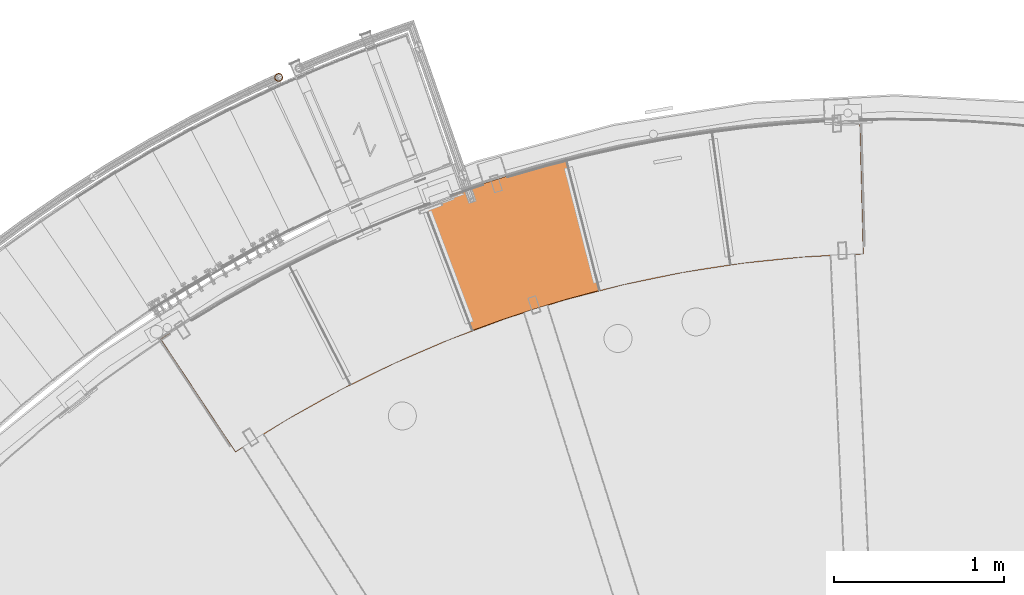
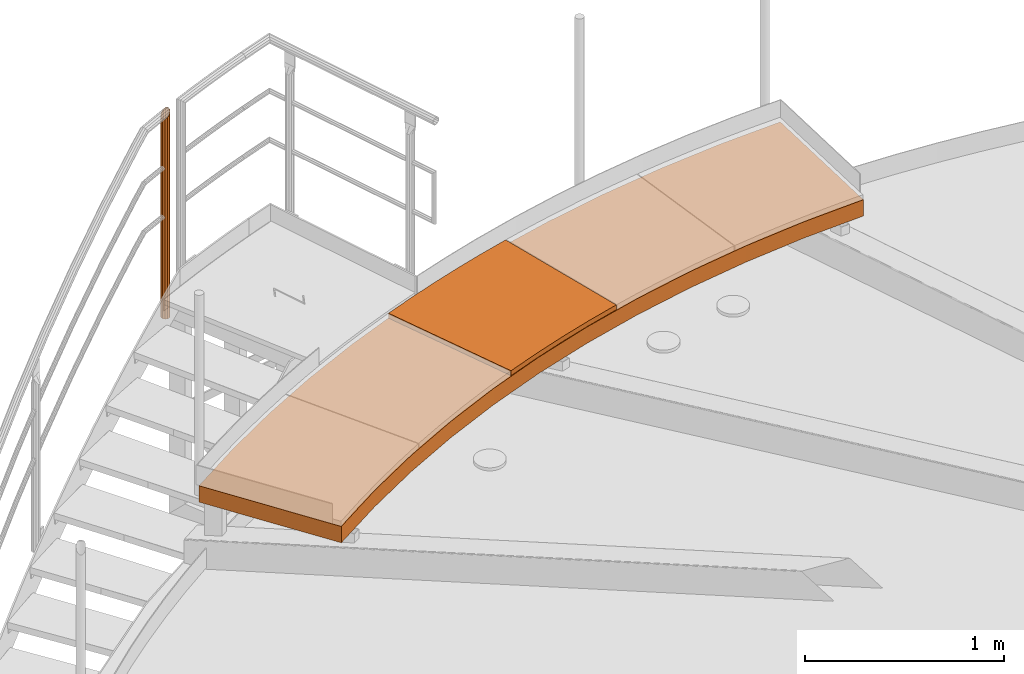
# One storey, part 38 of 126: 3 proxies.
"""IFC2X3 building model written with IfcOpenShell, lengths in millimetres."""

from ifc_helpers import new_model, si_unit, origin, origin_with_axes, place, context, project, spatial, faceted_brep, material, element, save


model = new_model("IFC2X3")

# Units and contexts
context_of_model_1 = context(None, 3, precision=0.1, world=origin())
context_of_model_2 = context(None, 3, precision=0.1, world=origin())
ifc_project = project(units=[si_unit("LENGTHUNIT", "METRE", prefix="MILLI"), si_unit("AREAUNIT", "SQUARE_METRE", prefix="CENTI"), si_unit("VOLUMEUNIT", "CUBIC_METRE", prefix="CENTI"), si_unit("MASSUNIT", "GRAM", prefix="KILO")], contexts=[context_of_model_1, context_of_model_2])

# Site, building, storey
site_placement = place(None, origin_with_axes())
site = spatial("IfcSite", under=ifc_project, at=site_placement, CompositionType="ELEMENT")
building_placement = place(site_placement, origin_with_axes())
building = spatial("IfcBuilding", under=site, at=building_placement, CompositionType="ELEMENT")
storey_placement = place(building_placement, origin_with_axes())
storey = spatial("IfcBuildingStorey", under=building, at=storey_placement, CompositionType="ELEMENT")

# Proxies
ifc_material_1 = material(Name="STAHL")
proxy_1_placement = place(storey_placement, origin_with_axes())
element("IfcBuildingElementProxy", 1, at=proxy_1_placement, inside=storey, material=ifc_material_1, Name="profile", context=context_of_model_2, shape_type="Brep", body=[
    faceted_brep([(3744.3, 14532.7, 10959.2), (4130.7, 13949.0, 10959.2), (4130.7, 13949.0, 10955.2), (3744.3, 14532.7, 10955.2), (3680.6, 14545.7, 10959.2), (3680.6, 14545.7, 11051.2), (4117.7, 13885.3, 11051.2), (4117.7, 13885.3, 10959.2), (3744.3, 14532.7, 11055.2), (4130.7, 13949.0, 11055.2), (4130.7, 13949.0, 11051.2), (3744.3, 14532.7, 11051.2), (3675.1, 14546.8, 11055.2), (3675.1, 14546.8, 10955.2), (4116.6, 13879.7, 10955.2), (4116.6, 13879.7, 11055.2), (4419.8, 14069.5, 10955.2), (4732.2, 14243.6, 10955.2), (5053.0, 14401.7, 10955.2), (5381.5, 14543.3, 10955.2), (5716.7, 14668.0, 10955.2), (6057.8, 14775.5, 10955.2), (6403.9, 14865.6, 10955.2), (6754.1, 14938.1, 10955.2), (7107.6, 14992.6, 10955.2), (7463.4, 15029.2, 10955.2), (7820.6, 15047.6, 10955.2), (7820.6, 15047.6, 11055.2), (7463.4, 15029.2, 11055.2), (7107.6, 14992.6, 11055.2), (6754.1, 14938.1, 11055.2), (6403.9, 14865.6, 11055.2), (6057.8, 14775.5, 11055.2), (5716.7, 14668.0, 11055.2), (5381.5, 14543.3, 11055.2), (5053.0, 14401.7, 11055.2), (4732.2, 14243.6, 11055.2), (4419.8, 14069.5, 11055.2), (4429.5, 14133.4, 10959.2), (4737.1, 14302.8, 10959.2), (5052.6, 14456.7, 10959.2), (5375.4, 14594.9, 10959.2), (5704.7, 14716.9, 10959.2), (6039.5, 14822.5, 10959.2), (6379.2, 14911.4, 10959.2), (6722.9, 14983.4, 10959.2), (7069.7, 15038.3, 10959.2), (7418.8, 15075.9, 10959.2), (7769.3, 15096.3, 10959.2), (7769.3, 15096.3, 10955.2), (7418.8, 15075.9, 10955.2), (7069.7, 15038.3, 10955.2), (6722.9, 14983.4, 10955.2), (6379.2, 14911.4, 10955.2), (6039.5, 14822.5, 10955.2), (5704.7, 14716.9, 10955.2), (5375.4, 14594.9, 10955.2), (5052.6, 14456.7, 10955.2), (4737.1, 14302.8, 10955.2), (4429.5, 14133.4, 10955.2), (4420.5, 14074.6, 11051.2), (4732.6, 14248.4, 11051.2), (5053.0, 14406.1, 11051.2), (5381.0, 14547.4, 11051.2), (5715.7, 14671.9, 11051.2), (6056.3, 14779.3, 11051.2), (6401.9, 14869.3, 11051.2), (6751.6, 14941.7, 11051.2), (7104.6, 14996.3, 11051.2), (7459.8, 15032.9, 11051.2), (7816.5, 15051.5, 11051.2), (7816.5, 15051.5, 10959.2), (7459.8, 15032.9, 10959.2), (7104.6, 14996.3, 10959.2), (6751.6, 14941.7, 10959.2), (6401.9, 14869.3, 10959.2), (6056.3, 14779.3, 10959.2), (5715.7, 14671.9, 10959.2), (5381.0, 14547.4, 10959.2), (5053.0, 14406.1, 10959.2), (4732.6, 14248.4, 10959.2), (4420.5, 14074.6, 10959.2), (4429.5, 14133.4, 11055.2), (4737.1, 14302.8, 11055.2), (5052.6, 14456.7, 11055.2), (5375.4, 14594.9, 11055.2), (5704.7, 14716.9, 11055.2), (6039.5, 14822.5, 11055.2), (6379.2, 14911.4, 11055.2), (6722.9, 14983.4, 11055.2), (7069.7, 15038.3, 11055.2), (7418.8, 15075.9, 11055.2), (7769.3, 15096.3, 11055.2), (7769.3, 15096.3, 11051.2), (7418.8, 15075.9, 11051.2), (7069.7, 15038.3, 11051.2), (6722.9, 14983.4, 11051.2), (6379.2, 14911.4, 11051.2), (6039.5, 14822.5, 11051.2), (5704.7, 14716.9, 11051.2), (5375.4, 14594.9, 11051.2), (5052.6, 14456.7, 11051.2), (4737.1, 14302.8, 11051.2), (4429.5, 14133.4, 11051.2), (4045.5, 14719.7, 11055.2), (4354.8, 14892.7, 11055.2), (4671.7, 15051.5, 11055.2), (4995.4, 15195.8, 11055.2), (5325.4, 15325.1, 11055.2), (5661.0, 15439.4, 11055.2), (6001.3, 15538.2, 11055.2), (6345.8, 15621.5, 11055.2), (6693.8, 15689.1, 11055.2), (7044.4, 15740.8, 11055.2), (7397.1, 15776.4, 11055.2), (7751.0, 15796.0, 11055.2), (7799.6, 15847.3, 11055.2), (7435.0, 15829.3, 11055.2), (7071.6, 15794.3, 11055.2), (6710.2, 15742.4, 11055.2), (6351.6, 15673.8, 11055.2), (5996.6, 15588.6, 11055.2), (5646.0, 15486.9, 11055.2), (5300.4, 15369.1, 11055.2), (4960.7, 15235.2, 11055.2), (4627.6, 15085.8, 11055.2), (4301.9, 14921.0, 11055.2), (3984.1, 14741.2, 11055.2), (7799.6, 15847.3, 10955.2), (3984.1, 14741.2, 10955.2), (4301.9, 14921.0, 10955.2), (4627.6, 15085.8, 10955.2), (4960.7, 15235.2, 10955.2), (5300.4, 15369.1, 10955.2), (5646.0, 15486.9, 10955.2), (5996.6, 15588.6, 10955.2), (6351.6, 15673.8, 10955.2), (6710.2, 15742.4, 10955.2), (7071.6, 15794.3, 10955.2), (7435.0, 15829.3, 10955.2), (7751.0, 15796.0, 10955.2), (7397.1, 15776.4, 10955.2), (7044.4, 15740.8, 10955.2), (6693.8, 15689.1, 10955.2), (6345.8, 15621.5, 10955.2), (6001.3, 15538.2, 10955.2), (5661.0, 15439.4, 10955.2), (5325.4, 15325.1, 10955.2), (4995.4, 15195.8, 10955.2), (4671.7, 15051.5, 10955.2), (4354.8, 14892.7, 10955.2), (4045.5, 14719.7, 10955.2), (7751.0, 15796.0, 10959.2), (4045.5, 14719.7, 10959.2), (4354.8, 14892.7, 10959.2), (4671.7, 15051.5, 10959.2), (4995.4, 15195.8, 10959.2), (5325.4, 15325.1, 10959.2), (5661.0, 15439.4, 10959.2), (6001.3, 15538.2, 10959.2), (6345.8, 15621.5, 10959.2), (6693.8, 15689.1, 10959.2), (7044.4, 15740.8, 10959.2), (7397.1, 15776.4, 10959.2), (7795.7, 15843.2, 10959.2), (7432.0, 15825.0, 10959.2), (7069.4, 15790.0, 10959.2), (6708.9, 15738.1, 10959.2), (6351.2, 15669.6, 10959.2), (5997.0, 15584.5, 10959.2), (5647.2, 15483.1, 10959.2), (5302.4, 15365.5, 10959.2), (4963.5, 15232.1, 10959.2), (4631.2, 15083.0, 10959.2), (4306.1, 14918.7, 10959.2), (3989.0, 14739.5, 10959.2), (7795.7, 15843.2, 11051.2), (3989.0, 14739.5, 11051.2), (4306.1, 14918.7, 11051.2), (4631.2, 15083.0, 11051.2), (4963.5, 15232.1, 11051.2), (5302.4, 15365.5, 11051.2), (5647.2, 15483.1, 11051.2), (5997.0, 15584.5, 11051.2), (6351.2, 15669.6, 11051.2), (6708.9, 15738.1, 11051.2), (7069.4, 15790.0, 11051.2), (7432.0, 15825.0, 11051.2), (7751.0, 15796.0, 11051.2), (7397.1, 15776.4, 11051.2), (7044.4, 15740.8, 11051.2), (6693.8, 15689.1, 11051.2), (6345.8, 15621.5, 11051.2), (6001.3, 15538.2, 11051.2), (5661.0, 15439.4, 11051.2), (5325.4, 15325.1, 11051.2), (4995.4, 15195.8, 11051.2), (4671.7, 15051.5, 11051.2), (4354.8, 14892.7, 11051.2), (4045.5, 14719.7, 11051.2)], [[[0, 1, 2, 3]], [[4, 5, 6, 7]], [[8, 9, 10, 11]], [[12, 13, 14, 15]], [[15, 14, 16, 17, 18, 19, 20, 21, 22, 23, 24, 25, 26, 27, 28, 29, 30, 31, 32, 33, 34, 35, 36, 37]], [[2, 1, 38, 39, 40, 41, 42, 43, 44, 45, 46, 47, 48, 49, 50, 51, 52, 53, 54, 55, 56, 57, 58, 59]], [[7, 6, 60, 61, 62, 63, 64, 65, 66, 67, 68, 69, 70, 71, 72, 73, 74, 75, 76, 77, 78, 79, 80, 81]], [[10, 9, 82, 83, 84, 85, 86, 87, 88, 89, 90, 91, 92, 93, 94, 95, 96, 97, 98, 99, 100, 101, 102, 103]], [[15, 37, 36, 35, 34, 33, 32, 88, 87, 86, 85, 84, 83, 82, 9, 8, 104, 105, 106, 107, 108, 109, 110, 111, 112, 113, 114, 115, 92, 91, 90, 89, 88, 32, 31, 30, 29, 28, 27, 116, 117, 118, 119, 120, 121, 122, 123, 124, 125, 126, 127, 12]], [[27, 26, 128, 116]], [[14, 13, 129, 130, 131, 132, 133, 134, 135, 136, 137, 138, 139, 128, 26, 25, 24, 23, 52, 51, 50, 49, 140, 141, 142, 143, 144, 145, 146, 147, 148, 149, 150, 151, 3, 2, 59, 58, 57, 56, 55, 54, 53, 52, 23, 22, 21, 20, 19, 18, 17, 16]], [[48, 152, 140, 49]], [[7, 81, 80, 79, 78, 77, 76, 44, 43, 42, 41, 40, 39, 38, 1, 0, 153, 154, 155, 156, 157, 158, 159, 160, 161, 162, 163, 152, 48, 47, 46, 45, 44, 76, 75, 74, 73, 72, 71, 164, 165, 166, 167, 168, 169, 170, 171, 172, 173, 174, 175, 4]], [[71, 70, 176, 164]], [[6, 5, 177, 178, 179, 180, 181, 182, 183, 184, 185, 186, 187, 176, 70, 69, 68, 67, 96, 95, 94, 93, 188, 189, 190, 191, 192, 193, 194, 195, 196, 197, 198, 199, 11, 10, 103, 102, 101, 100, 99, 98, 97, 96, 67, 66, 65, 64, 63, 62, 61, 60]], [[92, 115, 188, 93]], [[8, 11, 199, 198, 197, 196, 195, 194, 193, 192, 191, 190, 189, 188, 115, 114, 113, 112, 111, 110, 109, 108, 107, 106, 105, 104]], [[13, 12, 127, 126, 125, 124, 123, 122, 121, 120, 119, 118, 117, 116, 128, 139, 138, 137, 136, 135, 134, 133, 132, 131, 130, 129]], [[0, 3, 151, 150, 149, 148, 147, 146, 145, 144, 143, 142, 141, 140, 152, 163, 162, 161, 160, 159, 158, 157, 156, 155, 154, 153]], [[5, 4, 175, 174, 173, 172, 171, 170, 169, 168, 167, 166, 165, 164, 176, 187, 186, 185, 184, 183, 182, 181, 180, 179, 178, 177]]]),
])
proxy_2_placement = place(storey_placement, origin_with_axes())
element("IfcBuildingElementProxy", 2, at=proxy_2_placement, inside=storey, material=ifc_material_1, Name="profile", context=context_of_model_2, shape_type="Brep", body=[
    faceted_brep([(5515.9, 14597.8, 11085.2), (5515.9, 14597.8, 11055.2), (5700.0, 14664.4, 11055.2), (5885.9, 14725.8, 11055.2), (6073.4, 14782.1, 11055.2), (6262.5, 14833.2, 11055.2), (6262.5, 14833.2, 11085.2), (6073.4, 14782.1, 11085.2), (5885.9, 14725.8, 11085.2), (5700.0, 14664.4, 11085.2), (5234.6, 15342.4, 11085.2), (5234.6, 15342.4, 11055.2), (5398.4, 15402.2, 11085.2), (5563.5, 15458.3, 11085.2), (5729.9, 15510.8, 11085.2), (5897.3, 15559.5, 11085.2), (6065.8, 15604.5, 11085.2), (6065.8, 15604.5, 11055.2), (5897.3, 15559.5, 11055.2), (5729.9, 15510.8, 11055.2), (5563.5, 15458.3, 11055.2), (5398.4, 15402.2, 11055.2)], [[[0, 1, 2, 3, 4, 5, 6, 7, 8, 9]], [[0, 10, 11, 1]], [[11, 10, 12, 13, 14, 15, 16, 17, 18, 19, 20, 21]], [[17, 16, 6, 5]], [[0, 9, 8, 7, 6, 16, 15, 14, 13, 12, 10]], [[1, 11, 21, 20, 19, 18, 17, 5, 4, 3, 2]]]),
])
ifc_material_2 = material(Name="S235JRG2")
proxy_3_placement = place(storey_placement, origin_with_axes())
element("IfcBuildingElementProxy", 3, at=proxy_3_placement, inside=storey, material=ifc_material_2, Name="HANDLAUF", context=context_of_model_2, shape_type="Brep", body=[
    faceted_brep([(4393.2958, 16100.09, 10913.95), (4385.1754, 16109.594, 10913.95), (4385.1754, 16109.594, 12181.075), (4393.2958, 16100.09, 12184.649), (4395.576, 16087.799, 12181.785), (4395.576, 16087.799, 10913.95), (4391.4052, 16076.014, 12173.25), (4391.4052, 16076.014, 10913.95), (4381.9008, 16067.894, 12161.33), (4381.9008, 16067.894, 10913.95), (4369.6096, 16065.613, 12149.22), (4369.6096, 16065.613, 10913.95), (4357.8249, 16069.784, 12140.165), (4357.8249, 16069.784, 10913.95), (4349.7045, 16079.289, 12136.591), (4349.7045, 16079.289, 10913.95), (4347.4243, 16091.58, 12139.455), (4347.4243, 16091.58, 10913.95), (4351.5951, 16103.364, 12147.99), (4351.5951, 16103.364, 10913.95), (4361.0995, 16111.485, 12159.909), (4361.0995, 16111.485, 10913.95), (4373.3907, 16113.765, 12172.019), (4373.3907, 16113.765, 10913.95), (4373.195, 16111.273, 10913.95), (4383.7597, 16107.534, 10913.95), (4383.7597, 16107.534, 12178.957), (4373.195, 16111.273, 12170.839), (4362.1762, 16109.228, 12159.983), (4362.1762, 16109.228, 10913.95), (4353.6557, 16101.949, 12149.297), (4353.6557, 16101.949, 10913.95), (4349.9166, 16091.384, 12141.646), (4349.9166, 16091.384, 10913.95), (4351.9608, 16080.365, 12139.078), (4351.9608, 16080.365, 10913.95), (4359.2406, 16071.845, 12142.283), (4359.2406, 16071.845, 10913.95), (4369.8053, 16068.106, 12150.401), (4369.8053, 16068.106, 10913.95), (4380.8241, 16070.15, 12161.257), (4380.8241, 16070.15, 10913.95), (4389.3446, 16077.43, 12171.942), (4389.3446, 16077.43, 10913.95), (4393.0837, 16087.994, 12179.594), (4393.0837, 16087.994, 10913.95), (4391.0395, 16099.013, 12182.162), (4391.0395, 16099.013, 10913.95)], [[[0, 1, 2, 3]], [[0, 3, 4, 5]], [[5, 4, 6, 7]], [[7, 6, 8, 9]], [[9, 8, 10, 11]], [[11, 10, 12, 13]], [[13, 12, 14, 15]], [[15, 14, 16, 17]], [[17, 16, 18, 19]], [[19, 18, 20, 21]], [[21, 20, 22, 23]], [[1, 23, 22, 2]], [[24, 25, 26, 27]], [[24, 27, 28, 29]], [[29, 28, 30, 31]], [[31, 30, 32, 33]], [[33, 32, 34, 35]], [[35, 34, 36, 37]], [[37, 36, 38, 39]], [[39, 38, 40, 41]], [[41, 40, 42, 43]], [[43, 42, 44, 45]], [[45, 44, 46, 47]], [[25, 47, 46, 26]], [[19, 21, 23, 1, 0, 5, 7, 9, 11, 13, 15, 17], [24, 29, 31, 33, 35, 37, 39, 41, 43, 45, 47, 25]], [[14, 12, 10, 8, 6, 4, 3, 2, 22, 20, 18, 16], [26, 46, 44, 42, 40, 38, 36, 34, 32, 30, 28, 27]]]),
])

save(model, "model.ifc")
